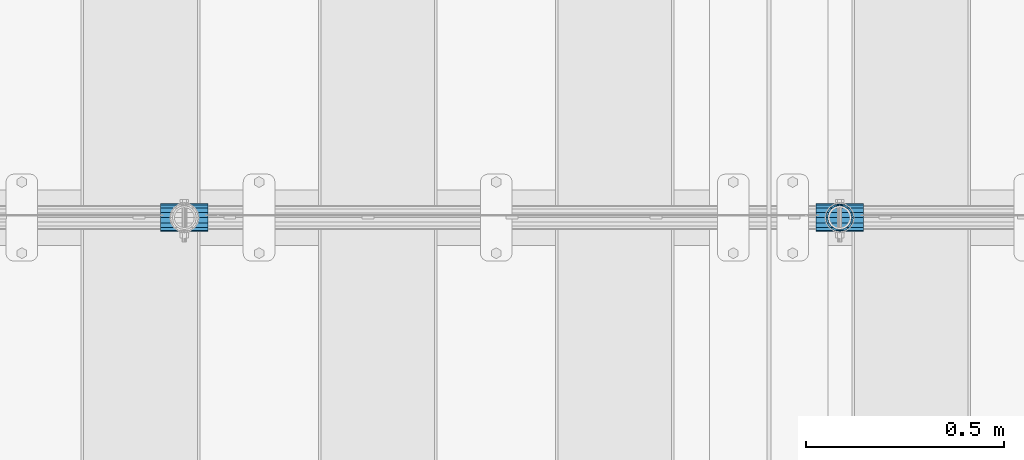
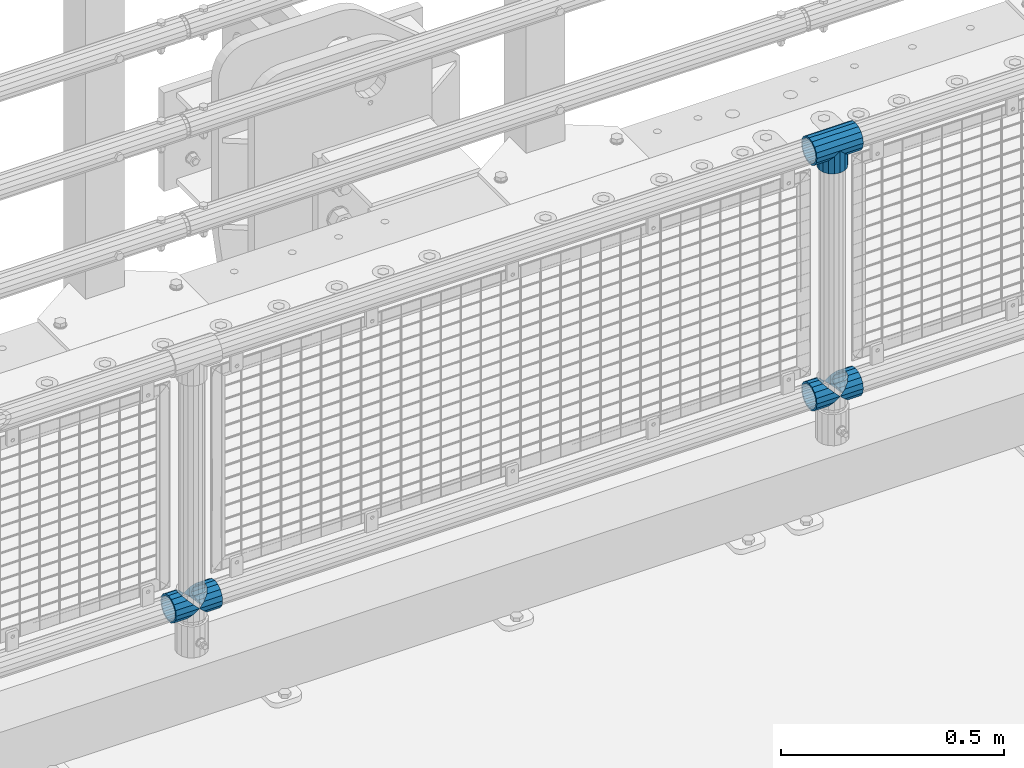
# One storey, part 154 of 240: 6 beams.
"""IFC2X3 building model written with IfcOpenShell, lengths in millimetres."""

from ifc_helpers import new_model, si_unit, frame, origin_with_axes, place, context, subcontext, project, spatial, faceted_brep, material, type_object, element, save


model = new_model("IFC2X3")

# Units and contexts
model_context = context("Model", 3, precision=1e-05, world=origin_with_axes())
body_context = subcontext(model_context, "Body", "Model", "MODEL_VIEW")
ifc_project = project(units=[si_unit("LENGTHUNIT", "METRE", prefix="MILLI"), si_unit("AREAUNIT", "SQUARE_METRE"), si_unit("VOLUMEUNIT", "CUBIC_METRE"), si_unit("MASSUNIT", "GRAM", prefix="KILO"), si_unit("TIMEUNIT", "SECOND"), si_unit("PLANEANGLEUNIT", "RADIAN"), si_unit("SOLIDANGLEUNIT", "STERADIAN"), si_unit("THERMODYNAMICTEMPERATUREUNIT", "DEGREE_CELSIUS"), si_unit("LUMINOUSINTENSITYUNIT", "LUMEN")], contexts=[model_context])

# Site, building, storey
site_placement = place(None, origin_with_axes())
site = spatial("IfcSite", under=ifc_project, at=site_placement, CompositionType="ELEMENT")
building_placement = place(site_placement, origin_with_axes())
building = spatial("IfcBuilding", under=site, at=building_placement, Name="Standard", CompositionType="ELEMENT")
storey_placement = place(building_placement, origin_with_axes())
storey = spatial("IfcBuildingStorey", under=building, at=storey_placement, Name="Undefined", CompositionType="ELEMENT", Elevation=0.0)

# Beams
ifc_material = material(Name="Misc_Undefined")
beam_type = type_object("IfcBeamType", PredefinedType="NOTDEFINED")
beam_1_placement = place(storey_placement, frame((53019.0, 34664.5, 969.849999999999), z_axis=(0.0, 1.0, 0.0), x_axis=(0.0, 0.0, -1.0)))
element("IfcBeam", 1, at=beam_1_placement, inside=storey, type_object=beam_type, material=ifc_material, context=body_context, shape_type="Brep", body=[
    faceted_brep([(0.0, 0.0, 35.1500000000015), (13.4513226476338, 13.4513226476329, 32.4743655677739), (13.4513226476338, -13.4513226476329, 32.4743655677739), (24.8548033587067, -16.3810424079947, -24.8548033587067), (24.8548033587067, -24.8548033587072, -24.8548033587067), (32.4743655677739, -32.4743655677717, -13.4513226476338), (32.4743655677739, -26.8123795176712, -13.4513226476338), (27.1226768591223, -21.4606908090117, -21.4606908090136), (0.0, 0.0, -35.1500000000015), (13.4513226476338, -13.4513226476329, -32.4743655677739), (13.4513226476338, 13.4513226476329, -32.4743655677739), (20.0882031229994, -11.6144421722805, -28.0397438117143), (16.6306603983758, 0.0, -30.3499999999985), (20.0882031229994, 11.6144421722805, -28.0397438117143), (24.8548033587067, 16.3810424080013, -24.8548033587067), (24.8548033587067, 24.8548033587072, -24.8548033587067), (27.1226768591223, 21.4606908090117, -21.4606908090136), (32.4743655677739, 26.8123795176712, -13.4513226476338), (32.4743655677739, 32.4743655677717, -13.4513226476338), (32.8397438117172, 28.0397438117175, -11.6144421722784), (35.1500000000015, 30.35, 0.0), (35.1500000000015, 35.15, 0.0), (32.8397438117099, 28.0397438117175, 11.6144421722784), (32.4743655677739, 26.8123795176755, 13.4513226476338), (32.4743655677739, 32.4743655677717, 13.4513226476338), (27.1226768591005, 21.4606908090117, 21.4606908090136), (24.8548033587067, 16.3810424080013, 24.8548033587067), (24.8548033587067, 24.8548033587072, 24.8548033587067), (20.0882031229849, 11.6144421722805, 28.0397438117143), (16.6306603983685, 0.0, 30.3499999999985), (20.0882031229849, -11.6144421722805, 28.0397438117143), (24.8548033587067, -16.3810424080078, 24.8548033587067), (24.8548033587067, -24.8548033587072, 24.8548033587067), (27.1226768591005, -21.4606908090117, 21.4606908090136), (32.4743655677739, -26.8123795176712, 13.4513226476338), (32.4743655677739, -32.4743655677717, 13.4513226476338), (32.8397438117099, -28.0397438117175, 11.6144421722784), (35.1500000000015, -30.35, 0.0), (35.1500000000015, -35.15, 0.0), (32.8397438117172, -28.0397438117175, -11.6144421722784), (60.1500000000015, -24.8548033587072, -24.8548033587067), (60.1500000000015, -32.4743655677717, -13.4513226476338), (60.1500000000015, -13.4513226476329, -32.4743655677739), (60.1500000000015, 0.0, -35.1500000000015), (60.1500000000015, 13.4513226476329, -32.4743655677739), (60.1500000000015, 24.8548033587072, -24.8548033587067), (60.1500000000015, 32.4743655677717, -13.4513226476338), (60.1500000000015, 35.15, 0.0), (60.1500000000015, 32.4743655677717, 13.4513226476338), (60.1500000000015, 24.8548033587072, 24.8548033587067), (60.1500000000015, 13.4513226476329, 32.4743655677739), (60.1500000000015, 0.0, 35.1500000000015), (60.1500000000015, -13.4513226476329, 32.4743655677739), (60.1500000000015, -24.8548033587072, 24.8548033587067), (60.1500000000015, -32.4743655677717, 13.4513226476338), (60.1500000000015, -35.15, 0.0), (60.1500000000015, -21.4606908090117, 21.4606908090136), (60.1500000000015, -11.6144421722805, 28.0397438117143), (60.1500000000015, 0.0, 30.3499999999985), (60.1500000000015, 11.6144421722805, 28.0397438117143), (60.1500000000015, 21.4606908090117, 21.4606908090136), (60.1500000000015, 28.0397438117175, 11.6144421722784), (60.1500000000015, 30.35, 0.0), (60.1500000000015, 28.0397438117175, -11.6144421722784), (60.1500000000015, 21.4606908090117, -21.4606908090136), (60.1500000000015, 11.6144421722805, -28.0397438117143), (60.1500000000015, 0.0, -30.3499999999985), (60.1500000000015, -11.6144421722805, -28.0397438117143), (60.1500000000015, -21.4606908090117, -21.4606908090136), (60.1500000000015, -28.0397438117175, -11.6144421722784), (60.1500000000015, -30.35, 0.0), (60.1500000000015, -28.0397438117175, 11.6144421722784)], [[[0, 1, 2]], [[3, 4, 5, 6, 7]], [[8, 9, 10]], [[10, 9, 4, 3, 11, 12, 13, 14, 15]], [[15, 14, 16, 17, 18]], [[18, 17, 19, 20, 21]], [[21, 20, 22, 23, 24]], [[24, 23, 25, 26, 27]], [[27, 26, 28, 29, 30, 31, 32, 2, 1]], [[33, 34, 35, 32, 31]], [[36, 37, 38, 35, 34]], [[6, 5, 38, 37, 39]], [[40, 41, 5, 4]], [[42, 40, 4, 9]], [[43, 42, 9, 8]], [[44, 43, 8, 10]], [[45, 44, 10, 15]], [[46, 45, 15, 18]], [[47, 46, 18, 21]], [[48, 47, 21, 24]], [[49, 48, 24, 27]], [[50, 49, 27, 1]], [[51, 50, 1, 0]], [[52, 51, 0, 2]], [[53, 52, 2, 32]], [[54, 53, 32, 35]], [[55, 54, 35, 38]], [[41, 55, 38, 5]], [[40, 42, 43, 44, 45, 46, 47, 48, 49, 50, 51, 52, 53, 54, 55, 41], [56, 57, 58, 59, 60, 61, 62, 63, 64, 65, 66, 67, 68, 69, 70, 71]], [[71, 70, 37, 36]], [[56, 71, 36, 34, 33]], [[57, 56, 33, 31, 30]], [[58, 57, 30, 29]], [[59, 58, 29, 28]], [[25, 60, 59, 28, 26]], [[22, 61, 60, 25, 23]], [[62, 61, 22, 20]], [[63, 62, 20, 19]], [[64, 63, 19, 17, 16]], [[65, 64, 16, 14, 13]], [[66, 65, 13, 12]], [[67, 66, 12, 11]], [[7, 68, 67, 11, 3]], [[39, 69, 68, 7, 6]], [[70, 69, 39, 37]]]),
])
beam_2_placement = place(storey_placement, frame((52958.85, 34664.5, 969.849999999999), z_axis=(0.0, 0.0, 1.0), x_axis=(1.0, 0.0, 0.0)))
element("IfcBeam", 2, at=beam_2_placement, inside=storey, type_object=beam_type, material=ifc_material, context=body_context, shape_type="Brep", body=[
    faceted_brep([(88.1897438117157, -11.6144421722784, -28.0397438117176), (88.1897438117157, -11.6144421722784, -32.8397438117188), (86.962379517674, -13.4513226476338, -32.4743655677718), (81.6106908090151, -21.4606908090136, -27.1226768591079), (81.6106908090151, -21.4606908090136, -21.4606908090117), (76.5310424080089, -24.8548033587067, -24.8548033587072), (71.7644421722798, -28.0397438117143, -20.0882031229927), (71.7644421722798, -28.0397438117143, -11.6144421722805), (60.1500000000015, -30.3499999999985, -16.6306603983737), (60.1500000000015, -30.35, 0.0), (48.5355578277231, -28.0397438117143, -20.0882031229927), (48.5355578277231, -28.0397438117143, -11.6144421722805), (43.7689575920012, -24.8548033587067, -24.8548033587072), (38.6893091909878, -21.4606908090136, -27.1226768591079), (38.6893091909878, -21.4606908090136, -21.4606908090117), (33.3376204823217, -13.4513226476338, -32.4743655677718), (32.1102561882872, -11.6144421722784, -32.8397438117188), (32.1102561882872, -11.6144421722784, -28.0397438117176), (29.8000000000029, 0.0, -35.15), (29.8000000000029, 0.0, -30.35), (32.1102561882872, 11.6144421722784, -32.8397438117188), (32.1102561882872, 11.6144421722784, -28.0397438117176), (33.3376204823362, 13.4513226476338, -32.4743655677718), (38.6893091909878, 21.4606908090136, -27.1226768591079), (38.6893091909878, 21.4606908090136, -21.4606908090117), (43.7689575919867, 24.8548033587067, -24.8548033587072), (48.5355578277231, 28.0397438117143, -20.0882031229927), (48.5355578277231, 28.0397438117143, -11.6144421722805), (60.1500000000015, 30.3499999999985, -16.6306603983737), (60.1500000000015, 30.35, 0.0), (71.7644421722798, 28.0397438117143, -20.0882031229927), (71.7644421722798, 28.0397438117143, -11.6144421722805), (76.5310424080017, 24.8548033587067, -24.8548033587072), (81.6106908090151, 21.4606908090136, -27.1226768591079), (81.6106908090151, 21.4606908090136, -21.4606908090117), (86.962379517674, 13.4513226476338, -32.4743655677718), (88.1897438117157, 11.6144421722784, -32.8397438117188), (88.1897438117157, 11.6144421722784, -28.0397438117176), (90.5, 0.0, -35.15), (90.5, 0.0, -30.35), (0.0, -21.4606908090136, -21.4606908090136), (0.0, -28.0397438117143, -11.6144421722784), (0.0, -11.6144421722784, -28.0397438117143), (0.0, 0.0, -30.3499999999985), (0.0, 11.6144421722784, -28.0397438117143), (0.0, 21.4606908090136, -21.4606908090136), (0.0, 28.0397438117143, -11.6144421722784), (0.0, 30.3499999999985, 0.0), (0.0, 32.4743655677739, -13.4513226476338), (0.0, 35.1500000000015, 0.0), (120.300000000003, 35.1500000000015, 0.0), (120.300000000003, 32.4743655677739, -13.4513226476329), (0.0, 32.4743655677739, 13.4513226476338), (120.300000000003, 32.4743655677739, 13.4513226476329), (0.0, 24.8548033587067, 24.8548033587067), (120.300000000003, 24.8548033587067, 24.8548033587072), (0.0, 13.4513226476338, 32.4743655677739), (120.300000000003, 13.4513226476338, 32.4743655677718), (0.0, 0.0, 35.1500000000015), (120.300000000003, 0.0, 35.15), (0.0, -13.4513226476338, 32.4743655677739), (120.300000000003, -13.4513226476338, 32.4743655677718), (0.0, -24.8548033587067, 24.8548033587067), (120.300000000003, -24.8548033587067, 24.8548033587072), (0.0, -32.4743655677739, 13.4513226476338), (120.300000000003, -32.4743655677739, 13.4513226476329), (0.0, -35.1500000000015, 0.0), (120.300000000003, -35.1500000000015, 0.0), (0.0, -32.4743655677739, -13.4513226476338), (120.300000000003, -32.4743655677739, -13.4513226476329), (0.0, 24.8548033587067, -24.8548033587067), (0.0, 13.4513226476338, -32.4743655677739), (0.0, 0.0, -35.1500000000015), (0.0, -13.4513226476338, -32.4743655677739), (0.0, -24.8548033587067, -24.8548033587067), (0.0, 28.0397438117143, 11.6144421722784), (0.0, 21.4606908090136, 21.4606908090136), (0.0, 11.6144421722784, 28.0397438117143), (0.0, 0.0, 30.3499999999985), (0.0, -11.6144421722784, 28.0397438117143), (0.0, -21.4606908090136, 21.4606908090136), (0.0, -28.0397438117143, 11.6144421722784), (0.0, -30.3499999999985, 0.0), (120.300000000003, -30.3499999999985, 0.0), (120.300000000003, -28.0397438117143, -11.6144421722805), (120.300000000003, -21.4606908090136, -21.4606908090117), (120.300000000003, -11.6144421722784, -28.0397438117176), (120.300000000003, 0.0, -30.35), (120.300000000003, 21.4606908090136, -21.4606908090117), (120.300000000003, 28.0397438117143, -11.6144421722805), (120.300000000003, 11.6144421722784, -28.0397438117176), (120.300000000003, 30.3499999999985, 0.0), (120.300000000003, 28.0397438117143, 11.6144421722805), (120.300000000003, 21.4606908090136, 21.4606908090117), (120.300000000003, 11.6144421722784, 28.0397438117176), (120.300000000003, 0.0, 30.35), (120.300000000003, -11.6144421722784, 28.0397438117176), (120.300000000003, -21.4606908090136, 21.4606908090117), (120.300000000003, -28.0397438117143, 11.6144421722805), (120.300000000003, -24.8548033587067, -24.8548033587072), (120.300000000003, -13.4513226476338, -32.4743655677718), (120.300000000003, 0.0, -35.15), (120.300000000003, 13.4513226476338, -32.4743655677718), (120.300000000003, 24.8548033587067, -24.8548033587072)], [[[0, 1, 2, 3, 4]], [[4, 3, 5, 6, 7]], [[7, 6, 8, 9]], [[9, 8, 10, 11]], [[11, 10, 12, 13, 14]], [[14, 13, 15, 16, 17]], [[17, 16, 18, 19]], [[19, 18, 20, 21]], [[21, 20, 22, 23, 24]], [[24, 23, 25, 26, 27]], [[27, 26, 28, 29]], [[29, 28, 30, 31]], [[31, 30, 32, 33, 34]], [[34, 33, 35, 36, 37]], [[37, 36, 38, 39]], [[39, 38, 1, 0]], [[40, 41, 11, 14]], [[42, 40, 14, 17]], [[43, 42, 17, 19]], [[44, 43, 19, 21]], [[45, 44, 21, 24]], [[46, 45, 24, 27]], [[47, 46, 27, 29]], [[48, 49, 50, 51]], [[49, 52, 53, 50]], [[52, 54, 55, 53]], [[54, 56, 57, 55]], [[56, 58, 59, 57]], [[58, 60, 61, 59]], [[60, 62, 63, 61]], [[62, 64, 65, 63]], [[64, 66, 67, 65]], [[66, 68, 69, 67]], [[64, 62, 60, 58, 56, 54, 52, 49, 48, 70, 71, 72, 73, 74, 68, 66], [41, 40, 42, 43, 44, 45, 46, 47, 75, 76, 77, 78, 79, 80, 81, 82]], [[41, 82, 9, 11]], [[83, 84, 7, 9]], [[84, 85, 4, 7]], [[85, 86, 0, 4]], [[86, 87, 39, 0]], [[88, 89, 31, 34]], [[90, 88, 34, 37]], [[87, 90, 37, 39]], [[89, 91, 29, 31]], [[75, 47, 29, 91, 92]], [[76, 75, 92, 93]], [[77, 76, 93, 94]], [[78, 77, 94, 95]], [[79, 78, 95, 96]], [[80, 79, 96, 97]], [[81, 80, 97, 98]], [[9, 82, 81, 98, 83]], [[99, 100, 101, 102, 103, 51, 50, 53, 55, 57, 59, 61, 63, 65, 67, 69], [97, 96, 95, 94, 93, 92, 91, 89, 88, 90, 87, 86, 85, 84, 83, 98]], [[35, 102, 101, 38, 36]], [[32, 103, 102, 35, 33]], [[28, 26, 25, 70, 48, 51, 103, 32, 30]], [[22, 71, 70, 25, 23]], [[18, 72, 71, 22, 20]], [[73, 72, 18, 16, 15]], [[74, 73, 15, 13, 12]], [[99, 69, 68, 74, 12, 10, 8, 6, 5]], [[100, 99, 5, 3, 2]], [[101, 100, 2, 1, 38]]]),
])
beam_3_placement = place(storey_placement, frame((51300.85, 34664.5, 298.17), z_axis=(0.0, 1.0, 0.0), x_axis=(1.0, 0.0, 0.0)))
element("IfcBeam", 3, at=beam_3_placement, inside=storey, type_object=beam_type, material=ifc_material, context=body_context, shape_type="Brep", body=[
    faceted_brep([(60.1500000000015, 0.0, -35.1500000000015), (46.6986773523677, 13.4513226476329, -32.4743655677739), (46.6986773523677, -13.4513226476329, -32.4743655677739), (33.0273231408937, 21.4606908090117, 21.4606908090136), (27.6756344322275, 26.8123795176712, 13.4513226476338), (27.6756344322275, 32.4743655677717, 13.4513226476338), (35.2951966412948, 24.8548033587072, 24.8548033587067), (35.2951966412948, 16.3810424080013, 24.8548033587067), (27.3102561882843, 28.0397438117175, 11.6144421722784), (25.0, 30.35, 0.0), (25.0, 35.15, 0.0), (27.6756344322275, 26.8123795176712, -13.4513226476338), (27.6756344322275, 32.4743655677717, -13.4513226476338), (27.3102561882843, 28.0397438117175, -11.6144421722784), (35.2951966412948, 16.3810424080078, -24.8548033587067), (35.2951966412948, 24.8548033587072, -24.8548033587067), (33.0273231408937, 21.4606908090117, -21.4606908090136), (40.0617968770021, 11.6144421722805, -28.0397438117143), (43.5193396016257, 0.0, -30.3499999999985), (40.0617968770021, -11.6144421722805, -28.0397438117143), (35.2951966412948, -16.3810424079948, -24.8548033587067), (35.2951966412948, -24.8548033587072, -24.8548033587067), (33.0273231408937, -21.4606908090117, -21.4606908090136), (27.6756344322275, -26.8123795176755, -13.4513226476338), (27.6756344322275, -32.4743655677717, -13.4513226476338), (27.3102561882843, -28.0397438117175, -11.6144421722784), (25.0, -30.35, 0.0), (25.0, -35.15, 0.0), (27.3102561882843, -28.0397438117175, 11.6144421722784), (27.6756344322275, -26.8123795176712, 13.4513226476338), (27.6756344322275, -32.4743655677717, 13.4513226476338), (33.0273231408937, -21.4606908090117, 21.4606908090136), (35.2951966412948, -16.3810424080078, 24.8548033587067), (35.2951966412948, -24.8548033587072, 24.8548033587067), (60.1500000000015, 0.0, 35.1500000000015), (46.6986773523677, -13.4513226476329, 32.4743655677739), (46.6986773523677, 13.4513226476329, 32.4743655677739), (40.0617968770093, -11.6144421722805, 28.0397438117143), (43.5193396016257, 0.0, 30.3499999999985), (40.0617968770093, 11.6144421722805, 28.0397438117143), (0.0, -32.4743655677739, -13.4513226476338), (0.0, -24.8548033587067, -24.8548033587067), (0.0, -13.4513226476338, -32.4743655677739), (0.0, 0.0, -35.1500000000015), (0.0, 13.4513226476338, -32.4743655677739), (0.0, 24.8548033587067, -24.8548033587067), (0.0, 32.4743655677739, -13.4513226476338), (0.0, 35.1500000000015, 0.0), (0.0, 32.4743655677739, 13.4513226476338), (0.0, 24.8548033587067, 24.8548033587067), (0.0, 13.4513226476338, 32.4743655677739), (0.0, 0.0, 35.1500000000015), (0.0, -32.4743655677739, 13.4513226476338), (0.0, -35.1500000000015, 0.0), (0.0, -24.8548033587067, 24.8548033587067), (0.0, -13.4513226476338, 32.4743655677739), (0.0, -28.0397438117143, -11.6144421722784), (0.0, -21.4606908090136, -21.4606908090136), (0.0, -11.6144421722784, -28.0397438117143), (0.0, 0.0, -30.3499999999985), (0.0, 11.6144421722784, -28.0397438117143), (0.0, 21.4606908090136, -21.4606908090136), (0.0, 28.0397438117143, -11.6144421722784), (0.0, 30.3499999999985, 0.0), (0.0, 28.0397438117143, 11.6144421722784), (0.0, 21.4606908090136, 21.4606908090136), (0.0, 11.6144421722784, 28.0397438117143), (0.0, 0.0, 30.3499999999985), (0.0, -11.6144421722784, 28.0397438117143), (0.0, -21.4606908090136, 21.4606908090136), (0.0, -28.0397438117143, 11.6144421722784), (0.0, -30.3499999999985, 0.0)], [[[0, 1, 2]], [[3, 4, 5, 6, 7]], [[8, 9, 10, 5, 4]], [[11, 12, 10, 9, 13]], [[14, 15, 12, 11, 16]], [[2, 1, 15, 14, 17, 18, 19, 20, 21]], [[21, 20, 22, 23, 24]], [[24, 23, 25, 26, 27]], [[27, 26, 28, 29, 30]], [[30, 29, 31, 32, 33]], [[34, 35, 36]], [[33, 32, 37, 38, 39, 7, 6, 36, 35]], [[40, 41, 21, 24]], [[41, 42, 2, 21]], [[42, 43, 0, 2]], [[43, 44, 1, 0]], [[44, 45, 15, 1]], [[45, 46, 12, 15]], [[46, 47, 10, 12]], [[47, 48, 5, 10]], [[48, 49, 6, 5]], [[49, 50, 36, 6]], [[50, 51, 34, 36]], [[52, 53, 27, 30]], [[54, 52, 30, 33]], [[55, 54, 33, 35]], [[51, 55, 35, 34]], [[53, 40, 24, 27]], [[52, 54, 55, 51, 50, 49, 48, 47, 46, 45, 44, 43, 42, 41, 40, 53], [56, 57, 58, 59, 60, 61, 62, 63, 64, 65, 66, 67, 68, 69, 70, 71]], [[68, 67, 38, 37]], [[31, 69, 68, 37, 32]], [[28, 70, 69, 31, 29]], [[71, 70, 28, 26]], [[56, 71, 26, 25]], [[57, 56, 25, 23, 22]], [[58, 57, 22, 20, 19]], [[59, 58, 19, 18]], [[60, 59, 18, 17]], [[16, 61, 60, 17, 14]], [[13, 62, 61, 16, 11]], [[63, 62, 13, 9]], [[64, 63, 9, 8]], [[65, 64, 8, 4, 3]], [[66, 65, 3, 7, 39]], [[67, 66, 39, 38]]]),
])
beam_4_placement = place(storey_placement, frame((51361.0, 34664.5, 298.17), z_axis=(0.0, 1.0, 0.0), x_axis=(1.0, 0.0, 0.0)))
element("IfcBeam", 4, at=beam_4_placement, inside=storey, type_object=beam_type, material=ifc_material, context=body_context, shape_type="Brep", body=[
    faceted_brep([(0.0, 0.0, 35.1500000000015), (13.4513226476338, 13.4513226476329, 32.4743655677739), (13.4513226476338, -13.4513226476329, 32.4743655677739), (24.8548033587067, -16.3810424079947, -24.8548033587067), (24.8548033587067, -24.8548033587072, -24.8548033587067), (32.4743655677739, -32.4743655677717, -13.4513226476338), (32.4743655677739, -26.8123795176712, -13.4513226476338), (27.1226768591223, -21.4606908090117, -21.4606908090136), (0.0, 0.0, -35.1500000000015), (13.4513226476338, -13.4513226476329, -32.4743655677739), (13.4513226476338, 13.4513226476329, -32.4743655677739), (20.0882031229994, -11.6144421722805, -28.0397438117143), (16.6306603983758, 0.0, -30.3499999999985), (20.0882031229994, 11.6144421722805, -28.0397438117143), (24.8548033587067, 16.3810424080013, -24.8548033587067), (24.8548033587067, 24.8548033587072, -24.8548033587067), (27.1226768591223, 21.4606908090117, -21.4606908090136), (32.4743655677739, 26.8123795176712, -13.4513226476338), (32.4743655677739, 32.4743655677717, -13.4513226476338), (32.8397438117172, 28.0397438117175, -11.6144421722784), (35.1500000000015, 30.35, 0.0), (35.1500000000015, 35.15, 0.0), (32.8397438117099, 28.0397438117175, 11.6144421722784), (32.4743655677739, 26.8123795176755, 13.4513226476338), (32.4743655677739, 32.4743655677717, 13.4513226476338), (27.1226768591005, 21.4606908090117, 21.4606908090136), (24.8548033587067, 16.3810424080013, 24.8548033587067), (24.8548033587067, 24.8548033587072, 24.8548033587067), (20.0882031229849, 11.6144421722805, 28.0397438117143), (16.6306603983685, 0.0, 30.3499999999985), (20.0882031229849, -11.6144421722805, 28.0397438117143), (24.8548033587067, -16.3810424080078, 24.8548033587067), (24.8548033587067, -24.8548033587072, 24.8548033587067), (27.1226768591005, -21.4606908090117, 21.4606908090136), (32.4743655677739, -26.8123795176712, 13.4513226476338), (32.4743655677739, -32.4743655677717, 13.4513226476338), (32.8397438117099, -28.0397438117175, 11.6144421722784), (35.1500000000015, -30.35, 0.0), (35.1500000000015, -35.15, 0.0), (32.8397438117172, -28.0397438117175, -11.6144421722784), (60.1500000000015, -24.8548033587072, -24.8548033587067), (60.1500000000015, -32.4743655677717, -13.4513226476338), (60.1500000000015, -13.4513226476329, -32.4743655677739), (60.1500000000015, 0.0, -35.1500000000015), (60.1500000000015, 13.4513226476329, -32.4743655677739), (60.1500000000015, 24.8548033587072, -24.8548033587067), (60.1500000000015, 32.4743655677717, -13.4513226476338), (60.1500000000015, 35.15, 0.0), (60.1500000000015, 32.4743655677717, 13.4513226476338), (60.1500000000015, 24.8548033587072, 24.8548033587067), (60.1500000000015, 13.4513226476329, 32.4743655677739), (60.1500000000015, 0.0, 35.1500000000015), (60.1500000000015, -13.4513226476329, 32.4743655677739), (60.1500000000015, -24.8548033587072, 24.8548033587067), (60.1500000000015, -32.4743655677717, 13.4513226476338), (60.1500000000015, -35.15, 0.0), (60.1500000000015, -21.4606908090117, 21.4606908090136), (60.1500000000015, -11.6144421722805, 28.0397438117143), (60.1500000000015, 0.0, 30.3499999999985), (60.1500000000015, 11.6144421722805, 28.0397438117143), (60.1500000000015, 21.4606908090117, 21.4606908090136), (60.1500000000015, 28.0397438117175, 11.6144421722784), (60.1500000000015, 30.35, 0.0), (60.1500000000015, 28.0397438117175, -11.6144421722784), (60.1500000000015, 21.4606908090117, -21.4606908090136), (60.1500000000015, 11.6144421722805, -28.0397438117143), (60.1500000000015, 0.0, -30.3499999999985), (60.1500000000015, -11.6144421722805, -28.0397438117143), (60.1500000000015, -21.4606908090117, -21.4606908090136), (60.1500000000015, -28.0397438117175, -11.6144421722784), (60.1500000000015, -30.35, 0.0), (60.1500000000015, -28.0397438117175, 11.6144421722784)], [[[0, 1, 2]], [[3, 4, 5, 6, 7]], [[8, 9, 10]], [[10, 9, 4, 3, 11, 12, 13, 14, 15]], [[15, 14, 16, 17, 18]], [[18, 17, 19, 20, 21]], [[21, 20, 22, 23, 24]], [[24, 23, 25, 26, 27]], [[27, 26, 28, 29, 30, 31, 32, 2, 1]], [[33, 34, 35, 32, 31]], [[36, 37, 38, 35, 34]], [[6, 5, 38, 37, 39]], [[40, 41, 5, 4]], [[42, 40, 4, 9]], [[43, 42, 9, 8]], [[44, 43, 8, 10]], [[45, 44, 10, 15]], [[46, 45, 15, 18]], [[47, 46, 18, 21]], [[48, 47, 21, 24]], [[49, 48, 24, 27]], [[50, 49, 27, 1]], [[51, 50, 1, 0]], [[52, 51, 0, 2]], [[53, 52, 2, 32]], [[54, 53, 32, 35]], [[55, 54, 35, 38]], [[41, 55, 38, 5]], [[40, 42, 43, 44, 45, 46, 47, 48, 49, 50, 51, 52, 53, 54, 55, 41], [56, 57, 58, 59, 60, 61, 62, 63, 64, 65, 66, 67, 68, 69, 70, 71]], [[71, 70, 37, 36]], [[56, 71, 36, 34, 33]], [[57, 56, 33, 31, 30]], [[58, 57, 30, 29]], [[59, 58, 29, 28]], [[25, 60, 59, 28, 26]], [[22, 61, 60, 25, 23]], [[62, 61, 22, 20]], [[63, 62, 20, 19]], [[64, 63, 19, 17, 16]], [[65, 64, 16, 14, 13]], [[66, 65, 13, 12]], [[67, 66, 12, 11]], [[7, 68, 67, 11, 3]], [[39, 69, 68, 7, 6]], [[70, 69, 39, 37]]]),
])
beam_5_placement = place(storey_placement, frame((52958.85, 34664.5, 298.17), z_axis=(0.0, 1.0, 0.0), x_axis=(1.0, 0.0, 0.0)))
element("IfcBeam", 5, at=beam_5_placement, inside=storey, type_object=beam_type, material=ifc_material, context=body_context, shape_type="Brep", body=[
    faceted_brep([(60.1500000000015, 0.0, -35.1500000000015), (46.6986773523677, 13.4513226476329, -32.4743655677739), (46.6986773523677, -13.4513226476329, -32.4743655677739), (33.0273231408937, 21.4606908090117, 21.4606908090136), (27.6756344322275, 26.8123795176712, 13.4513226476338), (27.6756344322275, 32.4743655677717, 13.4513226476338), (35.2951966412948, 24.8548033587072, 24.8548033587067), (35.2951966412948, 16.3810424080013, 24.8548033587067), (27.3102561882843, 28.0397438117175, 11.6144421722784), (25.0, 30.35, 0.0), (25.0, 35.15, 0.0), (27.6756344322275, 26.8123795176712, -13.4513226476338), (27.6756344322275, 32.4743655677717, -13.4513226476338), (27.3102561882843, 28.0397438117175, -11.6144421722784), (35.2951966412948, 16.3810424080078, -24.8548033587067), (35.2951966412948, 24.8548033587072, -24.8548033587067), (33.0273231408937, 21.4606908090117, -21.4606908090136), (40.0617968770021, 11.6144421722805, -28.0397438117143), (43.5193396016257, 0.0, -30.3499999999985), (40.0617968770021, -11.6144421722805, -28.0397438117143), (35.2951966412948, -16.3810424079948, -24.8548033587067), (35.2951966412948, -24.8548033587072, -24.8548033587067), (33.0273231408937, -21.4606908090117, -21.4606908090136), (27.6756344322275, -26.8123795176755, -13.4513226476338), (27.6756344322275, -32.4743655677717, -13.4513226476338), (27.3102561882843, -28.0397438117175, -11.6144421722784), (25.0, -30.35, 0.0), (25.0, -35.15, 0.0), (27.3102561882843, -28.0397438117175, 11.6144421722784), (27.6756344322275, -26.8123795176712, 13.4513226476338), (27.6756344322275, -32.4743655677717, 13.4513226476338), (33.0273231408937, -21.4606908090117, 21.4606908090136), (35.2951966412948, -16.3810424080078, 24.8548033587067), (35.2951966412948, -24.8548033587072, 24.8548033587067), (60.1500000000015, 0.0, 35.1500000000015), (46.6986773523677, -13.4513226476329, 32.4743655677739), (46.6986773523677, 13.4513226476329, 32.4743655677739), (40.0617968770093, -11.6144421722805, 28.0397438117143), (43.5193396016257, 0.0, 30.3499999999985), (40.0617968770093, 11.6144421722805, 28.0397438117143), (0.0, -32.4743655677739, -13.4513226476338), (0.0, -24.8548033587067, -24.8548033587067), (0.0, -13.4513226476338, -32.4743655677739), (0.0, 0.0, -35.1500000000015), (0.0, 13.4513226476338, -32.4743655677739), (0.0, 24.8548033587067, -24.8548033587067), (0.0, 32.4743655677739, -13.4513226476338), (0.0, 35.1500000000015, 0.0), (0.0, 32.4743655677739, 13.4513226476338), (0.0, 24.8548033587067, 24.8548033587067), (0.0, 13.4513226476338, 32.4743655677739), (0.0, 0.0, 35.1500000000015), (0.0, -32.4743655677739, 13.4513226476338), (0.0, -35.1500000000015, 0.0), (0.0, -24.8548033587067, 24.8548033587067), (0.0, -13.4513226476338, 32.4743655677739), (0.0, -28.0397438117143, -11.6144421722784), (0.0, -21.4606908090136, -21.4606908090136), (0.0, -11.6144421722784, -28.0397438117143), (0.0, 0.0, -30.3499999999985), (0.0, 11.6144421722784, -28.0397438117143), (0.0, 21.4606908090136, -21.4606908090136), (0.0, 28.0397438117143, -11.6144421722784), (0.0, 30.3499999999985, 0.0), (0.0, 28.0397438117143, 11.6144421722784), (0.0, 21.4606908090136, 21.4606908090136), (0.0, 11.6144421722784, 28.0397438117143), (0.0, 0.0, 30.3499999999985), (0.0, -11.6144421722784, 28.0397438117143), (0.0, -21.4606908090136, 21.4606908090136), (0.0, -28.0397438117143, 11.6144421722784), (0.0, -30.3499999999985, 0.0)], [[[0, 1, 2]], [[3, 4, 5, 6, 7]], [[8, 9, 10, 5, 4]], [[11, 12, 10, 9, 13]], [[14, 15, 12, 11, 16]], [[2, 1, 15, 14, 17, 18, 19, 20, 21]], [[21, 20, 22, 23, 24]], [[24, 23, 25, 26, 27]], [[27, 26, 28, 29, 30]], [[30, 29, 31, 32, 33]], [[34, 35, 36]], [[33, 32, 37, 38, 39, 7, 6, 36, 35]], [[40, 41, 21, 24]], [[41, 42, 2, 21]], [[42, 43, 0, 2]], [[43, 44, 1, 0]], [[44, 45, 15, 1]], [[45, 46, 12, 15]], [[46, 47, 10, 12]], [[47, 48, 5, 10]], [[48, 49, 6, 5]], [[49, 50, 36, 6]], [[50, 51, 34, 36]], [[52, 53, 27, 30]], [[54, 52, 30, 33]], [[55, 54, 33, 35]], [[51, 55, 35, 34]], [[53, 40, 24, 27]], [[52, 54, 55, 51, 50, 49, 48, 47, 46, 45, 44, 43, 42, 41, 40, 53], [56, 57, 58, 59, 60, 61, 62, 63, 64, 65, 66, 67, 68, 69, 70, 71]], [[68, 67, 38, 37]], [[31, 69, 68, 37, 32]], [[28, 70, 69, 31, 29]], [[71, 70, 28, 26]], [[56, 71, 26, 25]], [[57, 56, 25, 23, 22]], [[58, 57, 22, 20, 19]], [[59, 58, 19, 18]], [[60, 59, 18, 17]], [[16, 61, 60, 17, 14]], [[13, 62, 61, 16, 11]], [[63, 62, 13, 9]], [[64, 63, 9, 8]], [[65, 64, 8, 4, 3]], [[66, 65, 3, 7, 39]], [[67, 66, 39, 38]]]),
])
beam_6_placement = place(storey_placement, frame((53019.0, 34664.5, 298.17), z_axis=(0.0, 1.0, 0.0), x_axis=(1.0, 0.0, 0.0)))
element("IfcBeam", 6, at=beam_6_placement, inside=storey, type_object=beam_type, material=ifc_material, context=body_context, shape_type="Brep", body=[
    faceted_brep([(0.0, 0.0, 35.1500000000015), (13.4513226476338, 13.4513226476329, 32.4743655677739), (13.4513226476338, -13.4513226476329, 32.4743655677739), (24.8548033587067, -16.3810424079947, -24.8548033587067), (24.8548033587067, -24.8548033587072, -24.8548033587067), (32.4743655677739, -32.4743655677717, -13.4513226476338), (32.4743655677739, -26.8123795176712, -13.4513226476338), (27.1226768591223, -21.4606908090117, -21.4606908090136), (0.0, 0.0, -35.1500000000015), (13.4513226476338, -13.4513226476329, -32.4743655677739), (13.4513226476338, 13.4513226476329, -32.4743655677739), (20.0882031229994, -11.6144421722805, -28.0397438117143), (16.6306603983758, 0.0, -30.3499999999985), (20.0882031229994, 11.6144421722805, -28.0397438117143), (24.8548033587067, 16.3810424080013, -24.8548033587067), (24.8548033587067, 24.8548033587072, -24.8548033587067), (27.1226768591223, 21.4606908090117, -21.4606908090136), (32.4743655677739, 26.8123795176712, -13.4513226476338), (32.4743655677739, 32.4743655677717, -13.4513226476338), (32.8397438117172, 28.0397438117175, -11.6144421722784), (35.1500000000015, 30.35, 0.0), (35.1500000000015, 35.15, 0.0), (32.8397438117099, 28.0397438117175, 11.6144421722784), (32.4743655677739, 26.8123795176755, 13.4513226476338), (32.4743655677739, 32.4743655677717, 13.4513226476338), (27.1226768591005, 21.4606908090117, 21.4606908090136), (24.8548033587067, 16.3810424080013, 24.8548033587067), (24.8548033587067, 24.8548033587072, 24.8548033587067), (20.0882031229849, 11.6144421722805, 28.0397438117143), (16.6306603983685, 0.0, 30.3499999999985), (20.0882031229849, -11.6144421722805, 28.0397438117143), (24.8548033587067, -16.3810424080078, 24.8548033587067), (24.8548033587067, -24.8548033587072, 24.8548033587067), (27.1226768591005, -21.4606908090117, 21.4606908090136), (32.4743655677739, -26.8123795176712, 13.4513226476338), (32.4743655677739, -32.4743655677717, 13.4513226476338), (32.8397438117099, -28.0397438117175, 11.6144421722784), (35.1500000000015, -30.35, 0.0), (35.1500000000015, -35.15, 0.0), (32.8397438117172, -28.0397438117175, -11.6144421722784), (60.1500000000015, -24.8548033587072, -24.8548033587067), (60.1500000000015, -32.4743655677717, -13.4513226476338), (60.1500000000015, -13.4513226476329, -32.4743655677739), (60.1500000000015, 0.0, -35.1500000000015), (60.1500000000015, 13.4513226476329, -32.4743655677739), (60.1500000000015, 24.8548033587072, -24.8548033587067), (60.1500000000015, 32.4743655677717, -13.4513226476338), (60.1500000000015, 35.15, 0.0), (60.1500000000015, 32.4743655677717, 13.4513226476338), (60.1500000000015, 24.8548033587072, 24.8548033587067), (60.1500000000015, 13.4513226476329, 32.4743655677739), (60.1500000000015, 0.0, 35.1500000000015), (60.1500000000015, -13.4513226476329, 32.4743655677739), (60.1500000000015, -24.8548033587072, 24.8548033587067), (60.1500000000015, -32.4743655677717, 13.4513226476338), (60.1500000000015, -35.15, 0.0), (60.1500000000015, -21.4606908090117, 21.4606908090136), (60.1500000000015, -11.6144421722805, 28.0397438117143), (60.1500000000015, 0.0, 30.3499999999985), (60.1500000000015, 11.6144421722805, 28.0397438117143), (60.1500000000015, 21.4606908090117, 21.4606908090136), (60.1500000000015, 28.0397438117175, 11.6144421722784), (60.1500000000015, 30.35, 0.0), (60.1500000000015, 28.0397438117175, -11.6144421722784), (60.1500000000015, 21.4606908090117, -21.4606908090136), (60.1500000000015, 11.6144421722805, -28.0397438117143), (60.1500000000015, 0.0, -30.3499999999985), (60.1500000000015, -11.6144421722805, -28.0397438117143), (60.1500000000015, -21.4606908090117, -21.4606908090136), (60.1500000000015, -28.0397438117175, -11.6144421722784), (60.1500000000015, -30.35, 0.0), (60.1500000000015, -28.0397438117175, 11.6144421722784)], [[[0, 1, 2]], [[3, 4, 5, 6, 7]], [[8, 9, 10]], [[10, 9, 4, 3, 11, 12, 13, 14, 15]], [[15, 14, 16, 17, 18]], [[18, 17, 19, 20, 21]], [[21, 20, 22, 23, 24]], [[24, 23, 25, 26, 27]], [[27, 26, 28, 29, 30, 31, 32, 2, 1]], [[33, 34, 35, 32, 31]], [[36, 37, 38, 35, 34]], [[6, 5, 38, 37, 39]], [[40, 41, 5, 4]], [[42, 40, 4, 9]], [[43, 42, 9, 8]], [[44, 43, 8, 10]], [[45, 44, 10, 15]], [[46, 45, 15, 18]], [[47, 46, 18, 21]], [[48, 47, 21, 24]], [[49, 48, 24, 27]], [[50, 49, 27, 1]], [[51, 50, 1, 0]], [[52, 51, 0, 2]], [[53, 52, 2, 32]], [[54, 53, 32, 35]], [[55, 54, 35, 38]], [[41, 55, 38, 5]], [[40, 42, 43, 44, 45, 46, 47, 48, 49, 50, 51, 52, 53, 54, 55, 41], [56, 57, 58, 59, 60, 61, 62, 63, 64, 65, 66, 67, 68, 69, 70, 71]], [[71, 70, 37, 36]], [[56, 71, 36, 34, 33]], [[57, 56, 33, 31, 30]], [[58, 57, 30, 29]], [[59, 58, 29, 28]], [[25, 60, 59, 28, 26]], [[22, 61, 60, 25, 23]], [[62, 61, 22, 20]], [[63, 62, 20, 19]], [[64, 63, 19, 17, 16]], [[65, 64, 16, 14, 13]], [[66, 65, 13, 12]], [[67, 66, 12, 11]], [[7, 68, 67, 11, 3]], [[39, 69, 68, 7, 6]], [[70, 69, 39, 37]]]),
])

save(model, "model.ifc")
